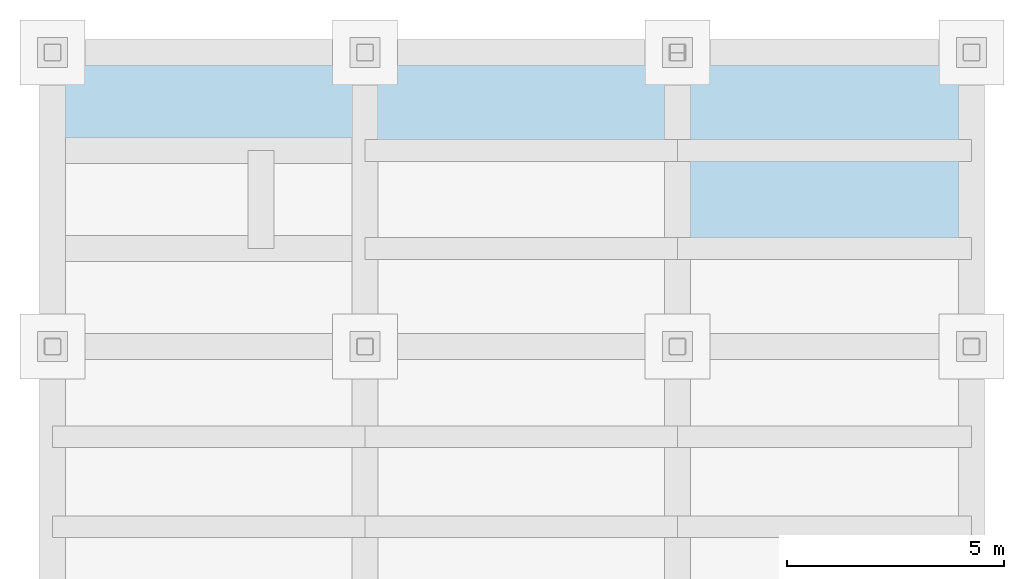
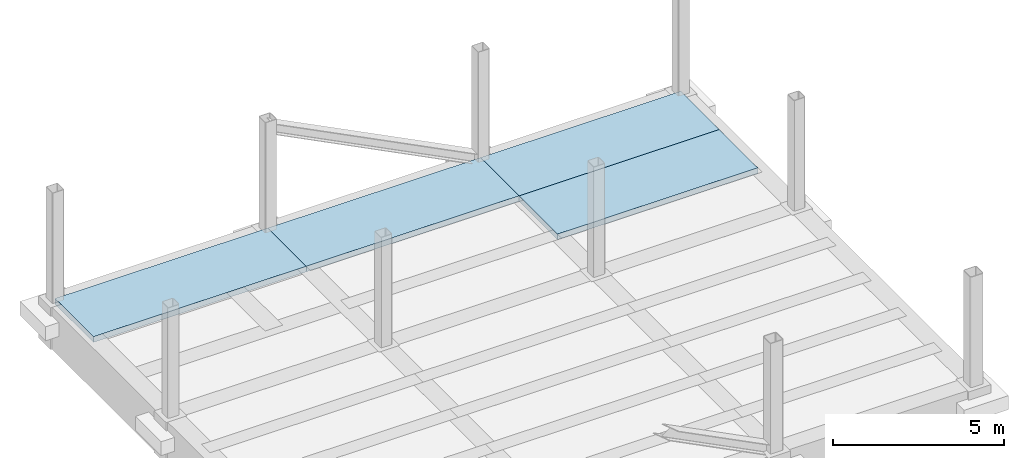
# One storey, part 2 of 2: 4 slabs.
"""IFC2X3 building model written with IfcOpenShell, lengths in millimetres."""

from ifc_helpers import new_model, si_unit, frame, origin_with_axes, place, context, subcontext, project, spatial, polyline, outline, extrude, material, layer, layer_set, layer_usage, type_object, element, save


model = new_model("IFC2X3")

# Units and contexts
model_context = context("Model", 3, precision=1e-05, world=origin_with_axes())
body_context = subcontext(model_context, "Body", "Model", "MODEL_VIEW")
ifc_project = project(units=[si_unit("LENGTHUNIT", "METRE", prefix="MILLI"), si_unit("AREAUNIT", "SQUARE_METRE"), si_unit("VOLUMEUNIT", "CUBIC_METRE"), si_unit("MASSUNIT", "GRAM", prefix="KILO"), si_unit("TIMEUNIT", "SECOND"), si_unit("PLANEANGLEUNIT", "RADIAN"), si_unit("SOLIDANGLEUNIT", "STERADIAN"), si_unit("THERMODYNAMICTEMPERATUREUNIT", "DEGREE_CELSIUS"), si_unit("LUMINOUSINTENSITYUNIT", "LUMEN")], contexts=[model_context])

# Site, building, storey
site_placement = place(None, origin_with_axes())
site = spatial("IfcSite", under=ifc_project, at=site_placement, CompositionType="ELEMENT")
building_placement = place(site_placement, origin_with_axes())
building = spatial("IfcBuilding", under=site, at=building_placement, Name="Undefined", CompositionType="ELEMENT")
storey_placement = place(building_placement, origin_with_axes())
storey = spatial("IfcBuildingStorey", under=building, at=storey_placement, Name="1", CompositionType="ELEMENT", Elevation=0.0)

# Slabs
ifc_material = material(Name="CONCRETE/FC24")
ifc_layer = layer(ifc_material, 200.0)
ifc_layer_set = layer_set([ifc_layer], Name="Floor: Insitu CONCRETE/FC24")
ifc_layer_usage_1 = layer_usage(ifc_layer_set, "AXIS3", "POSITIVE", -100.0)
slab_type = type_object("IfcSlabType", PredefinedType="NOTDEFINED")
slab_1_placement = place(storey_placement, frame((36000.0, 12633.3, 100.0), z_axis=(0.0, 0.0, 1.0), x_axis=(1.0, 0.0, 0.0)))
element("IfcSlab", 1, at=slab_1_placement, inside=storey, type_object=slab_type, material=ifc_layer_usage_1, Name="1SB6.2", PredefinedType="FLOOR", context=body_context, shape_type="SweptSolid", body=[
    extrude(outline(polyline([(0.0, 0.0), (6775.0, 0.0), (6775.0, 1341.69995117188), (6775.0, 2258.39990234375), (0.0, 2258.39990234375), (0.0, 1341.69995117188), (0.0, 0.0)])), frame((0.0, 0.0, -100.0), z_axis=(0.0, 0.0, 1.0), x_axis=(1.0, 0.0, 0.0)), (0.0, 0.0, 1.0), 200.0),
])
ifc_layer_usage_2 = layer_usage(ifc_layer_set, "AXIS3", "POSITIVE", -100.0)
slab_2_placement = place(storey_placement, frame((36000.0, 14891.7, 100.0), z_axis=(0.0, 0.0, 1.0), x_axis=(1.0, 0.0, 0.0)))
element("IfcSlab", 2, at=slab_2_placement, inside=storey, type_object=slab_type, material=ifc_layer_usage_2, Name="1SB6.3", PredefinedType="FLOOR", context=body_context, shape_type="SweptSolid", body=[
    extrude(outline(polyline([(0.0, 0.0), (6775.0, 0.0), (6775.0, 2258.30004882813), (0.0, 2258.30004882813), (0.0, 0.0)])), frame((0.0, 0.0, -100.0), z_axis=(0.0, 0.0, 1.0), x_axis=(1.0, 0.0, 0.0)), (0.0, 0.0, 1.0), 200.0),
])
ifc_layer_usage_3 = layer_usage(ifc_layer_set, "AXIS3", "POSITIVE", -100.0)
slab_3_placement = place(storey_placement, frame((28800.0, 14891.7, 100.0), z_axis=(0.0, 0.0, 1.0), x_axis=(1.0, 0.0, 0.0)))
element("IfcSlab", 3, at=slab_3_placement, inside=storey, type_object=slab_type, material=ifc_layer_usage_3, Name="1SB5.3", PredefinedType="FLOOR", context=body_context, shape_type="SweptSolid", body=[
    extrude(outline(polyline([(0.0, 0.0), (7200.0, 0.0), (7200.0, 2258.30004882813), (0.0, 2258.30004882813), (0.0, 0.0)])), frame((0.0, 0.0, -100.0), z_axis=(0.0, 0.0, 1.0), x_axis=(1.0, 0.0, 0.0)), (0.0, 0.0, 1.0), 200.0),
])
ifc_layer_usage_4 = layer_usage(ifc_layer_set, "AXIS3", "POSITIVE", -100.0)
slab_4_placement = place(storey_placement, frame((21600.0, 14891.7, 100.0), z_axis=(0.0, 0.0, 1.0), x_axis=(1.0, 0.0, 0.0)))
element("IfcSlab", 4, at=slab_4_placement, inside=storey, type_object=slab_type, material=ifc_layer_usage_4, Name="1SB4.3", PredefinedType="FLOOR", context=body_context, shape_type="SweptSolid", body=[
    extrude(outline(polyline([(0.0, 0.0), (7200.0, 0.0), (7200.0, 2258.30004882813), (0.0, 2258.30004882813), (0.0, 0.0)])), frame((0.0, 0.0, -100.0), z_axis=(0.0, 0.0, 1.0), x_axis=(1.0, 0.0, 0.0)), (0.0, 0.0, 1.0), 200.0),
])

save(model, "model.ifc")
